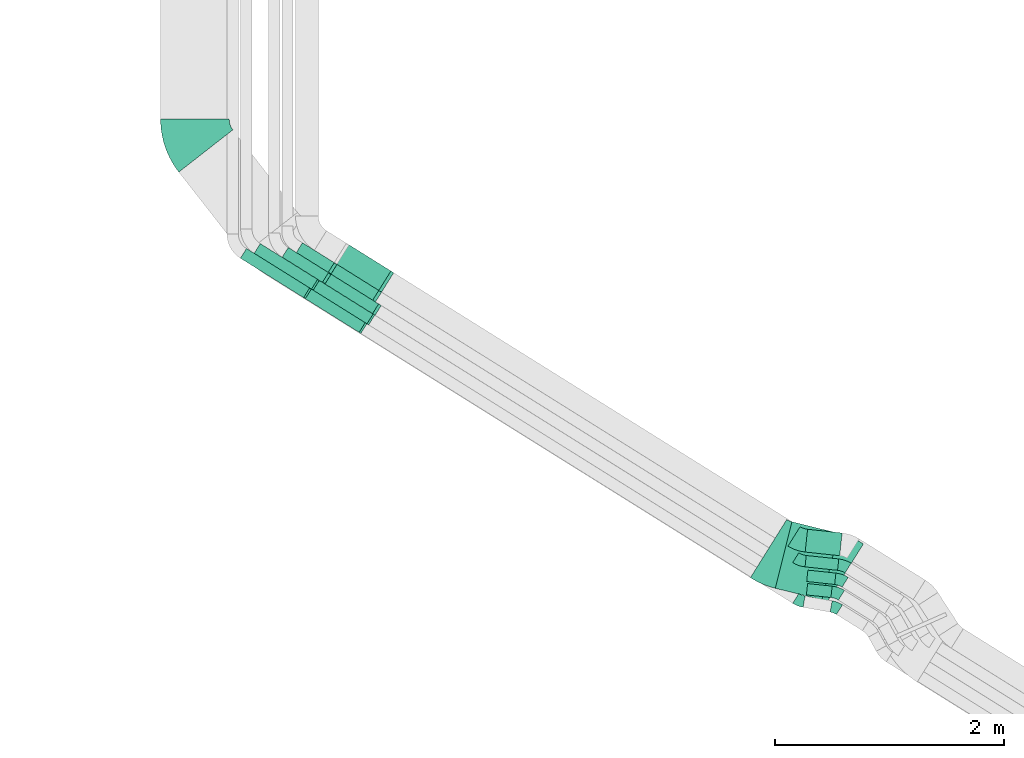
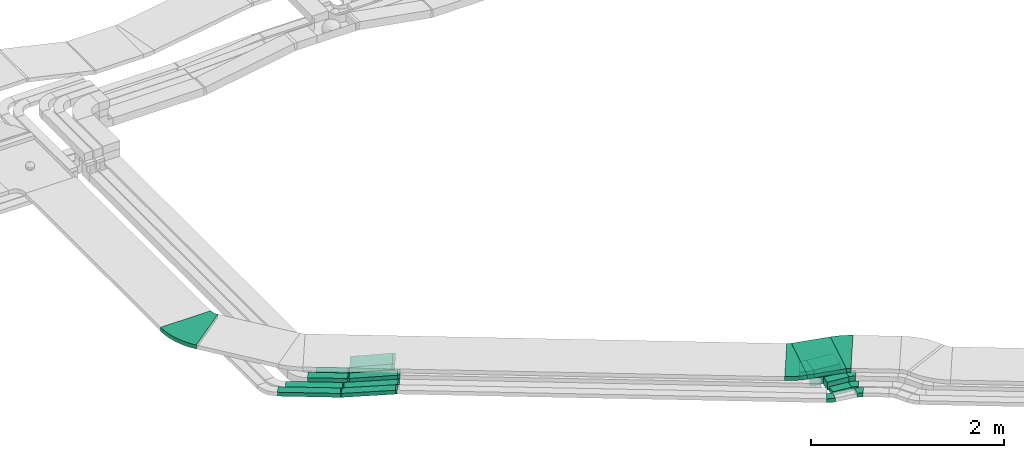
# One storey, part 5 of 28: 19 flow fittings, 14 flow segments.
"""IFC2X3 building model written with IfcOpenShell, lengths in millimetres."""

from ifc_helpers import new_model, entity, si_unit, converted_unit, derived_unit, direction, frame, frame_2d, origin, origin_2d_with_axis, place, context, subcontext, project, spatial, polyline, circle_curve, parameter, trimmed, segment, composite_curve, rectangle, outline, extrude, faceted_brep, source, transform, mapped, material, type_object, type_shapes, element, save


model = new_model("IFC2X3")

# Units and contexts
model_context = context("Model", 3, precision=0.01, world=origin(), true_north=direction((6.12303176911189e-17, 1.0)))
body_context = subcontext(model_context, "Body", "Model", "MODEL_VIEW")
ifc_project = project(units=[si_unit("LENGTHUNIT", "METRE", prefix="MILLI"), si_unit("AREAUNIT", "SQUARE_METRE"), si_unit("VOLUMEUNIT", "CUBIC_METRE"), converted_unit("PLANEANGLEUNIT", "DEGREE", entity("IfcRatioMeasure", 0.0174532925199433), si_unit("PLANEANGLEUNIT", "RADIAN"), dimensions=[0, 0, 0, 0, 0, 0, 0]), si_unit("MASSUNIT", "GRAM", prefix="KILO"), derived_unit("MASSDENSITYUNIT", [(si_unit("MASSUNIT", "GRAM", prefix="KILO"), 1), (si_unit("LENGTHUNIT", "METRE"), -3)]), derived_unit("MOMENTOFINERTIAUNIT", [(si_unit("LENGTHUNIT", "METRE"), 4)]), si_unit("TIMEUNIT", "SECOND"), si_unit("FREQUENCYUNIT", "HERTZ"), si_unit("THERMODYNAMICTEMPERATUREUNIT", "DEGREE_CELSIUS"), derived_unit("THERMALTRANSMITTANCEUNIT", [(si_unit("MASSUNIT", "GRAM", prefix="KILO"), 1), (si_unit("THERMODYNAMICTEMPERATUREUNIT", "KELVIN"), -1), (si_unit("TIMEUNIT", "SECOND"), -3)]), derived_unit("VOLUMETRICFLOWRATEUNIT", [(si_unit("LENGTHUNIT", "METRE"), 3), (si_unit("TIMEUNIT", "SECOND"), -1)]), derived_unit("MASSFLOWRATEUNIT", [(si_unit("MASSUNIT", "GRAM", prefix="KILO"), 1), (si_unit("TIMEUNIT", "SECOND"), -1)]), derived_unit("ROTATIONALFREQUENCYUNIT", [(si_unit("TIMEUNIT", "SECOND"), -1)]), si_unit("ELECTRICCURRENTUNIT", "AMPERE"), si_unit("ELECTRICVOLTAGEUNIT", "VOLT"), si_unit("POWERUNIT", "WATT"), si_unit("FORCEUNIT", "NEWTON", prefix="KILO"), si_unit("ILLUMINANCEUNIT", "LUX"), si_unit("LUMINOUSFLUXUNIT", "LUMEN"), si_unit("LUMINOUSINTENSITYUNIT", "CANDELA"), derived_unit("USERDEFINED", [(si_unit("MASSUNIT", "GRAM", prefix="KILO"), -1), (si_unit("LENGTHUNIT", "METRE"), -2), (si_unit("TIMEUNIT", "SECOND"), 3), (si_unit("LUMINOUSFLUXUNIT", "LUMEN"), 1)]), derived_unit("LINEARVELOCITYUNIT", [(si_unit("LENGTHUNIT", "METRE"), 1), (si_unit("TIMEUNIT", "SECOND"), -1)]), si_unit("PRESSUREUNIT", "PASCAL"), derived_unit("USERDEFINED", [(si_unit("LENGTHUNIT", "METRE"), -2), (si_unit("MASSUNIT", "GRAM", prefix="KILO"), 1), (si_unit("TIMEUNIT", "SECOND"), -2)]), derived_unit("LINEARFORCEUNIT", [(si_unit("MASSUNIT", "GRAM", prefix="KILO"), 1), (si_unit("LENGTHUNIT", "METRE"), 1), (si_unit("TIMEUNIT", "SECOND"), -2), (si_unit("LENGTHUNIT", "METRE"), -1)]), derived_unit("PLANARFORCEUNIT", [(si_unit("MASSUNIT", "GRAM", prefix="KILO"), 1), (si_unit("LENGTHUNIT", "METRE"), 1), (si_unit("TIMEUNIT", "SECOND"), -2), (si_unit("LENGTHUNIT", "METRE"), -2)])], contexts=[model_context])

# Site, building, storey
site_placement = place(None, origin())
site = spatial("IfcSite", under=ifc_project, at=site_placement, CompositionType="ELEMENT")
building_placement = place(site_placement, origin())
building = spatial("IfcBuilding", under=site, at=building_placement, CompositionType="ELEMENT")
storey_placement = place(building_placement, frame((0.0, 0.0, 4200.0)))
storey = spatial("IfcBuildingStorey", under=building, at=storey_placement, CompositionType="ELEMENT", Elevation=4200.0)

# Flow segments
cable_carrier_segment_type = type_object("IfcCableCarrierSegmentType", PredefinedType="CABLETRAYSEGMENT")
flow_segment_1_placement = place(storey_placement, frame((11021.96, 6012.63, 2780.0)))
element("IfcFlowSegment", 1, at=flow_segment_1_placement, inside=storey, type_object=cable_carrier_segment_type, context=body_context, shape_type="SweptSolid", body=[
    extrude(rectangle(XDim=590.779348946736, YDim=99.9999999999992, at=origin_2d_with_axis()), frame((277.0, 198.94, 0.0), z_axis=(0.0, 0.0, 1.0), x_axis=(-0.848048096156395, 0.529919264233255, 0.0)), (0.0, 0.0, 1.0), 49.9999999999995),
])
flow_segment_2_placement = place(storey_placement, frame((10901.96, 5937.63, 2780.0)))
element("IfcFlowSegment", 2, at=flow_segment_2_placement, inside=storey, type_object=cable_carrier_segment_type, context=body_context, shape_type="SweptSolid", body=[
    extrude(rectangle(XDim=650.976943556377, YDim=99.9999999999992, at=origin_2d_with_axis()), frame((302.53, 214.89, 0.0), z_axis=(0.0, 0.0, 1.0), x_axis=(-0.848048096156398, 0.529919264233251, 0.0)), (0.0, 0.0, 1.0), 49.9999999999994),
])
flow_segment_3_placement = place(storey_placement, frame((15850.33, 3315.86, 2836.0)))
element("IfcFlowSegment", 3, at=flow_segment_3_placement, inside=storey, type_object=cable_carrier_segment_type, context=body_context, shape_type="SweptSolid", body=[
    extrude(rectangle(XDim=215.79362758406, YDim=99.9999999999994, at=origin_2d_with_axis()), frame((112.59, 61.16, 0.0), z_axis=(0.0, 0.0, 1.0), x_axis=(0.994358083083249, -0.106075457137867, 0.0)), (0.0, 0.0, 1.0), 49.9999999999994),
])
flow_segment_4_placement = place(storey_placement, frame((15852.98, 3430.12, 2836.0)))
element("IfcFlowSegment", 4, at=flow_segment_4_placement, inside=storey, type_object=cable_carrier_segment_type, context=body_context, shape_type="SweptSolid", body=[
    extrude(rectangle(XDim=245.980376559461, YDim=99.9999999999996, at=origin_2d_with_axis()), frame((127.6, 62.76, 0.0), z_axis=(0.0, 0.0, 1.0), x_axis=(0.994358083083258, -0.106075457137776, 0.0)), (0.0, 0.0, 1.0), 99.9999999999989),
])
flow_segment_5_placement = place(storey_placement, frame((15838.53, 3553.72, 2836.0)))
element("IfcFlowSegment", 5, at=flow_segment_5_placement, inside=storey, type_object=cable_carrier_segment_type, context=body_context, shape_type="SweptSolid", body=[
    extrude(rectangle(XDim=285.980376559459, YDim=99.9999999999996, at=origin_2d_with_axis()), frame((147.49, 64.89, 0.0), z_axis=(0.0, 0.0, 1.0), x_axis=(0.994358083083257, -0.106075457137787, 0.0)), (0.0, 0.0, 1.0), 99.9999999999989),
])
flow_segment_6_placement = place(storey_placement, frame((15839.58, 3681.5, 2836.0)))
element("IfcFlowSegment", 6, at=flow_segment_6_placement, inside=storey, type_object=cable_carrier_segment_type, context=body_context, shape_type="SweptSolid", body=[
    extrude(rectangle(XDim=303.568110682782, YDim=200.0, at=origin_2d_with_axis()), frame((161.54, 115.54, 0.0), z_axis=(0.0, 0.0, 1.0), x_axis=(0.994358083083256, -0.106075457137793, 0.0)), (0.0, 0.0, 1.0), 99.9999999999989),
])
flow_segment_7_placement = place(storey_placement, frame((15578.61, 3295.28, 3108.85)))
element("IfcFlowSegment", 7, at=flow_segment_7_placement, inside=storey, type_object=cable_carrier_segment_type, context=body_context, shape_type="SweptSolid", body=[
    extrude(rectangle(XDim=419.986776604596, YDim=600.000000000001, at=origin_2d_with_axis()), frame((276.33, 341.89, 0.0), z_axis=(0.0, 0.0, 1.0), x_axis=(0.970295726275994, -0.241921895599679, 0.0)), (0.0, 0.0, 1.0), 49.9999999999995),
])
flow_segment_8_placement = place(storey_placement, frame((11464.95, 5631.66, 2780.86)))
element("IfcFlowSegment", 8, at=flow_segment_8_placement, inside=storey, type_object=cable_carrier_segment_type, context=body_context, shape_type="SweptSolid", body=[
    extrude(rectangle(XDim=50.0000000000007, YDim=100.0, at=frame_2d((0.0, 0.0), x_axis=(0.0, 1.0))), frame((28.55, 340.27, 24.88), z_axis=(0.844053853043885, -0.527423384128046, 0.0969415650621141), x_axis=(0.529919264233164, 0.848048096156452, 0.0)), (0.0, 0.0, 1.0), 562.323215441914),
])
flow_segment_9_placement = place(storey_placement, frame((11533.9, 5706.65, 2780.86)))
element("IfcFlowSegment", 9, at=flow_segment_9_placement, inside=storey, type_object=cable_carrier_segment_type, context=body_context, shape_type="SweptSolid", body=[
    extrude(rectangle(XDim=50.0000000000008, YDim=99.9999999999974, at=origin_2d_with_axis()), frame((28.55, 340.27, 24.88), z_axis=(0.844053853043877, -0.527423384128054, 0.0969415650621368), x_axis=(-0.0822111096893616, 0.0513712028313554, 0.995290074783881)), (0.0, 0.0, 1.0), 562.323215441913),
])
flow_segment_10_placement = place(storey_placement, frame((11632.32, 5792.33, 2781.42)))
element("IfcFlowSegment", 10, at=flow_segment_10_placement, inside=storey, type_object=cable_carrier_segment_type, context=body_context, shape_type="SweptSolid", body=[
    extrude(rectangle(XDim=100.0, YDim=100.000000000001, at=origin_2d_with_axis()), frame((31.02, 310.67, 49.71), z_axis=(0.843210160257302, -0.526896186363397, 0.106663182188436), x_axis=(-0.0904555085848854, 0.0565228750260753, 0.994295210470933)), (0.0, 0.0, 1.0), 503.785479436427),
])
flow_segment_11_placement = place(storey_placement, frame((11266.96, 6071.81, 2780.0)))
element("IfcFlowSegment", 11, at=flow_segment_11_placement, inside=storey, type_object=cable_carrier_segment_type, context=body_context, shape_type="SweptSolid", body=[
    extrude(rectangle(XDim=414.985433178406, YDim=99.9999999999999, at=origin_2d_with_axis()), frame((202.46, 152.36, 0.0), z_axis=(0.0, 0.0, 1.0), x_axis=(-0.848048096156469, 0.529919264233136, 0.0)), (0.0, 0.0, 1.0), 100.000000000002),
])
flow_segment_12_placement = place(storey_placement, frame((11683.6, 5909.58, 2781.71)))
element("IfcFlowSegment", 12, at=flow_segment_12_placement, inside=storey, type_object=cable_carrier_segment_type, context=body_context, shape_type="SweptSolid", body=[
    extrude(rectangle(XDim=100.0, YDim=100.0, at=frame_2d((0.0, 0.0), x_axis=(0.0, 1.0))), frame((31.57, 279.84, 49.64), z_axis=(0.841952241120385, -0.526110151247443, 0.119685138704662), x_axis=(0.529919264233164, 0.848048096156452, 0.0)), (0.0, 0.0, 1.0), 445.282079813443),
])
flow_segment_13_placement = place(storey_placement, frame((11736.83, 5994.77, 2781.71)))
element("IfcFlowSegment", 13, at=flow_segment_13_placement, inside=storey, type_object=cable_carrier_segment_type, context=body_context, shape_type="SweptSolid", body=[
    extrude(rectangle(XDim=99.9999999999993, YDim=200.0, at=frame_2d((0.0, 0.0), x_axis=(0.0, 1.0))), frame((58.07, 322.24, 49.64), z_axis=(0.841952241120382, -0.526110151247425, 0.119685138704764), x_axis=(0.529919264233197, 0.848048096156431, 0.0)), (0.0, 0.0, 1.0), 445.282079812818),
])
flow_segment_14_placement = place(storey_placement, frame((11391.08, 6158.96, 2780.0)))
element("IfcFlowSegment", 14, at=flow_segment_14_placement, inside=storey, type_object=cable_carrier_segment_type, context=body_context, shape_type="SweptSolid", body=[
    extrude(rectangle(XDim=328.386911704391, YDim=99.9999999999992, at=origin_2d_with_axis()), frame((165.74, 129.41, 0.0), z_axis=(0.0, 0.0, 1.0), x_axis=(-0.848048096156503, 0.529919264233081, 0.0)), (0.0, 0.0, 1.0), 99.9999999999989),
])

# Flow fittings
ifc_material = material()
cable_carrier_fitting_type_1 = type_object("IfcCableCarrierFittingType", PredefinedType="NOTDEFINED", material=ifc_material)
shared_shape_1 = source(origin(), body_context, "Body", "Brep", [
    faceted_brep([(-7.67, -25.0, 50.0), (-7.67, 25.0, 50.0), (-7.67, 25.0, 47.46), (-7.67, -22.46, 47.46), (-7.67, -22.46, -47.46), (-7.67, 25.0, -47.46), (-7.67, 25.0, -50.0), (-7.67, -25.0, -50.0), (10.06, -24.14, 50.0), (10.06, -24.14, -50.0), (5.21, 25.63, -50.0), (5.21, 25.63, -47.46), (9.81, -21.61, -47.46), (9.81, -21.61, 47.46), (5.21, 25.63, 47.46), (5.21, 25.63, 50.0), (1.21, -25.0, 50.0), (-1.21, 25.0, 50.0), (-1.21, 25.0, 47.46), (1.09, -22.46, 47.46), (1.09, -22.46, -47.46), (-1.21, 25.0, -47.46), (-1.21, 25.0, -50.0), (1.21, -25.0, -50.0)], [[[0, 1, 2, 3, 4, 5, 6, 7]], [[8, 9, 10, 11, 12, 13, 14, 15]], [[1, 0, 16, 8, 15, 17]], [[2, 1, 17, 18]], [[3, 2, 18, 14, 13, 19]], [[4, 3, 19, 20]], [[5, 4, 20, 12, 11, 21]], [[6, 5, 21, 22]], [[7, 6, 22, 10, 9, 23]], [[0, 7, 23, 16]], [[18, 17, 15, 14]], [[20, 19, 13, 12]], [[22, 21, 11, 10]], [[16, 23, 9, 8]]]),
])
type_shapes(cable_carrier_fitting_type_1, [shared_shape_1])
for number, where, z_axis, x_axis in (
    (15, (11974.6, 5671.3, 2861.0), (-0.529919264233211, -0.848048096156423, 0.0), (-0.848048096156423, 0.529919264233211, 0.0)),
    (16, (12043.55, 5746.29, 2861.0), (-0.52991926423321, -0.848048096156423, 0.0), (-0.848048096156423, 0.52991926423321, 0.0)),
    (17, (11555.97, 6050.97, 2805.0), (0.529919264233259, 0.848048096156392, 0.0), (-0.84405385304387, 0.527423384128066, -0.0969415650621308)),
    (18, (11487.02, 5975.97, 2805.0), (0.529919264233254, 0.848048096156395, 0.0), (-0.844053853043888, 0.527423384128036, -0.0969415650621345)),
):
    element("IfcFlowFitting", number, at=place(storey_placement, frame(where, z_axis=z_axis, x_axis=x_axis)), inside=storey, type_object=cable_carrier_fitting_type_1, material=ifc_material, context=body_context, shape_type="MappedRepresentation", body=[
        mapped(shared_shape_1, transform((0.0, 0.0, 0.0), scale=1.0)),
    ])
cable_carrier_fitting_type_2 = type_object("IfcCableCarrierFittingType", PredefinedType="NOTDEFINED", material=ifc_material)
shared_shape_2 = source(origin(), body_context, "Body", "Brep", [
    faceted_brep([(-10.62, -50.0, 50.0), (-10.62, 50.0, 50.0), (-10.62, 50.0, 47.46), (-10.62, -47.46, 47.46), (-10.62, -47.46, -47.46), (-10.62, 50.0, -47.46), (-10.62, 50.0, -50.0), (-10.62, -50.0, -50.0), (15.89, -48.58, 50.0), (15.89, -48.58, -50.0), (5.22, 50.85, -50.0), (5.22, 50.85, -47.46), (15.62, -46.06, -47.46), (15.62, -46.06, 47.46), (5.22, 50.85, 47.46), (5.22, 50.85, 50.0), (2.67, -50.0, 50.0), (-2.67, 50.0, 50.0), (-2.67, 50.0, 47.46), (2.54, -47.46, 47.46), (2.54, -47.46, -47.46), (-2.67, 50.0, -47.46), (-2.67, 50.0, -50.0), (2.67, -50.0, -50.0)], [[[0, 1, 2, 3, 4, 5, 6, 7]], [[8, 9, 10, 11, 12, 13, 14, 15]], [[1, 0, 16, 8, 15, 17]], [[2, 1, 17, 18]], [[3, 2, 18, 14, 13, 19]], [[4, 3, 19, 20]], [[5, 4, 20, 12, 11, 21]], [[6, 5, 21, 22]], [[7, 6, 22, 10, 9, 23]], [[0, 7, 23, 16]], [[18, 17, 15, 14]], [[20, 19, 13, 12]], [[22, 21, 11, 10]], [[16, 23, 9, 8]]]),
])
type_shapes(cable_carrier_fitting_type_2, [shared_shape_2])
for number, where, z_axis, x_axis in (
    (19, (12097.09, 5831.96, 2886.0), (-0.52991926423321, -0.848048096156423, 0.0), (-0.848048096156423, 0.52991926423321, 0.0)),
    (20, (11654.39, 6108.59, 2830.0), (0.529919264233145, 0.848048096156463, 0.0), (-0.843210160257299, 0.526896186363399, -0.106663182188447)),
):
    element("IfcFlowFitting", number, at=place(storey_placement, frame(where, z_axis=z_axis, x_axis=x_axis)), inside=storey, type_object=cable_carrier_fitting_type_2, material=ifc_material, context=body_context, shape_type="MappedRepresentation", body=[
        mapped(shared_shape_2, transform((0.0, 0.0, 0.0), scale=1.0)),
    ])
cable_carrier_fitting_type_3 = type_object("IfcCableCarrierFittingType", PredefinedType="NOTDEFINED", material=ifc_material)
shared_shape_3 = source(origin(), body_context, "Body", "Brep", [
    faceted_brep([(-11.31, -50.0, 50.0), (-11.31, 50.0, 50.0), (-11.31, 50.0, 47.46), (-11.31, -47.46, 47.46), (-11.31, -47.46, -47.46), (-11.31, 50.0, -47.46), (-11.31, 50.0, -50.0), (-11.31, -50.0, -50.0), (17.21, -48.29, 50.0), (17.21, -48.29, -50.0), (5.24, 50.99, -50.0), (5.24, 50.99, -47.46), (16.91, -45.77, -47.46), (16.91, -45.77, 47.46), (5.24, 50.99, 47.46), (5.24, 50.99, 50.0), (3.0, -50.0, 50.0), (-3.0, 50.0, 50.0), (-3.0, 50.0, 47.46), (2.85, -47.46, 47.46), (2.85, -47.46, -47.46), (-3.0, 50.0, -47.46), (-3.0, 50.0, -50.0), (3.0, -50.0, -50.0)], [[[0, 1, 2, 3, 4, 5, 6, 7]], [[8, 9, 10, 11, 12, 13, 14, 15]], [[1, 0, 16, 8, 15, 17]], [[2, 1, 17, 18]], [[3, 2, 18, 14, 13, 19]], [[4, 3, 19, 20]], [[5, 4, 20, 12, 11, 21]], [[6, 5, 21, 22]], [[7, 6, 22, 10, 9, 23]], [[0, 7, 23, 16]], [[18, 17, 15, 14]], [[20, 19, 13, 12]], [[22, 21, 11, 10]], [[16, 23, 9, 8]]]),
])
type_shapes(cable_carrier_fitting_type_3, [shared_shape_3])
for number, where, z_axis, x_axis in (
    (21, (11705.65, 6195.37, 2830.0), (-0.529919264233235, -0.848048096156407, 0.0), (0.848048096156407, -0.529919264233235, 0.0)),
    (22, (12099.6, 5949.21, 2886.0), (-0.529919264233217, -0.848048096156419, 0.0), (-0.848048096156419, 0.529919264233217, 0.0)),
):
    element("IfcFlowFitting", number, at=place(storey_placement, frame(where, z_axis=z_axis, x_axis=x_axis)), inside=storey, type_object=cable_carrier_fitting_type_3, material=ifc_material, context=body_context, shape_type="MappedRepresentation", body=[
        mapped(shared_shape_3, transform((0.0, 0.0, 0.0), scale=1.0)),
    ])
cable_carrier_fitting_type_4 = type_object("IfcCableCarrierFittingType", PredefinedType="NOTDEFINED", material=ifc_material)
shared_shape_4 = source(origin(), body_context, "Body", "Brep", [
    faceted_brep([(-11.31, -50.0, 100.0), (-11.31, 50.0, 100.0), (-11.31, 50.0, 97.46), (-11.31, -47.46, 97.46), (-11.31, -47.46, -97.46), (-11.31, 50.0, -97.46), (-11.31, 50.0, -100.0), (-11.31, -50.0, -100.0), (17.21, -48.29, 100.0), (17.21, -48.29, -100.0), (5.24, 50.99, -100.0), (5.24, 50.99, -97.46), (16.91, -45.77, -97.46), (16.91, -45.77, 97.46), (5.24, 50.99, 97.46), (5.24, 50.99, 100.0), (3.0, -50.0, 100.0), (-3.0, 50.0, 100.0), (-3.0, 50.0, 97.46), (2.85, -47.46, 97.46), (2.85, -47.46, -97.46), (-3.0, 50.0, -97.46), (-3.0, 50.0, -100.0), (3.0, -50.0, -100.0)], [[[0, 1, 2, 3, 4, 5, 6, 7]], [[8, 9, 10, 11, 12, 13, 14, 15]], [[1, 0, 16, 8, 15, 17]], [[2, 1, 17, 18]], [[3, 2, 18, 14, 13, 19]], [[4, 3, 19, 20]], [[5, 4, 20, 12, 11, 21]], [[6, 5, 21, 22]], [[7, 6, 22, 10, 9, 23]], [[0, 7, 23, 16]], [[18, 17, 15, 14]], [[20, 19, 13, 12]], [[22, 21, 11, 10]], [[16, 23, 9, 8]]]),
])
type_shapes(cable_carrier_fitting_type_4, [shared_shape_4])
flow_fitting_1_placement = place(storey_placement, frame((12179.33, 6076.8, 2886.0), z_axis=(0.529919264233213, 0.848048096156421, 0.0), x_axis=(0.841952241120384, -0.526110151247419, 0.119685138704774)))
element("IfcFlowFitting", 23, at=flow_fitting_1_placement, inside=storey, type_object=cable_carrier_fitting_type_4, material=ifc_material, context=body_context, shape_type="MappedRepresentation", body=[
    mapped(shared_shape_4, transform((0.0, 0.0, 0.0), scale=1.0)),
])
cable_carrier_fitting_type_5 = type_object("IfcCableCarrierFittingType", Name="470_DKC_S5_Variable Angle Elbow 0-45:-", PredefinedType="NOTDEFINED", material=ifc_material)
shared_shape_5 = source(origin(), body_context, "Body", "SweptSolid", [
    extrude(outline(composite_curve([segment(polyline([(-38.44, -57.38), (-37.44, -57.38)]), True, "CONTINUOUS"), segment(trimmed(circle_curve(frame_2d((-37.44, 192.62), x_axis=(0.0, -1.0)), 250.0), [parameter(0.0)], [parameter(22.0)], True, "PARAMETER"), True, "CONTINUOUS"), segment(polyline([(56.21, -39.17), (57.14, -38.8)]), True, "CONTINUOUS"), segment(polyline([(57.14, -38.8), (19.68, 53.92)]), True, "CONTINUOUS"), segment(polyline([(19.68, 53.92), (18.75, 53.55)]), True, "CONTINUOUS"), segment(trimmed(circle_curve(frame_2d((-37.44, 192.62), x_axis=(0.0, -1.0)), 150.0), [parameter(0.0)], [parameter(22.0)], True, "PARAMETER"), False, "CONTINUOUS"), segment(polyline([(-37.44, 42.62), (-38.44, 42.62)]), True, "CONTINUOUS"), segment(polyline([(-38.44, 42.62), (-38.44, -57.38)]), True, "CONTINUOUS")], self_intersect=False)), frame((-1.43, 7.38, -25.0)), (0.0, 0.0, 1.0), 50.0000000000001),
])
type_shapes(cable_carrier_fitting_type_5, [shared_shape_5])
for number, where, z_axis, x_axis, name in (
    (24, (15790.82, 3286.66, 2861.0), (0.0, 0.0, 1.0), (0.848048096156424, -0.529919264233208, 0.0), "470_DKC_S5_Variable Angle Elbow 0-45:-"),
    (25, (16105.96, 3231.09, 2861.0), (0.0, 0.0, 1.0), (-0.848048096156422, 0.529919264233211, 0.0), "470_DKC_S5_Variable Angle Elbow 0-45:-"),
):
    element("IfcFlowFitting", number, at=place(storey_placement, frame(where, z_axis=z_axis, x_axis=x_axis)), inside=storey, type_object=cable_carrier_fitting_type_5, material=ifc_material, Name=name, ObjectType="470_DKC_S5_Variable Angle Elbow 0-45:-", context=body_context, shape_type="MappedRepresentation", body=[
        mapped(shared_shape_5, transform((0.0, 0.0, 0.0), scale=1.0)),
    ])
cable_carrier_fitting_type_6 = type_object("IfcCableCarrierFittingType", Name="470_DKC_S5_Variable Angle Elbow 0-45:-", PredefinedType="NOTDEFINED", material=ifc_material)
shared_shape_6 = source(origin(), body_context, "Body", "SweptSolid", [
    extrude(outline(composite_curve([segment(polyline([(-44.67, -60.16), (-43.67, -60.16)]), True, "CONTINUOUS"), segment(trimmed(circle_curve(frame_2d((-43.67, 189.84), x_axis=(0.0, -1.0)), 250.0), [parameter(0.0)], [parameter(25.9108682245421)], True, "PARAMETER"), True, "CONTINUOUS"), segment(polyline([(65.57, -35.03), (66.47, -34.59)]), True, "CONTINUOUS"), segment(polyline([(66.47, -34.59), (22.77, 55.35)]), True, "CONTINUOUS"), segment(polyline([(22.77, 55.35), (21.87, 54.92)]), True, "CONTINUOUS"), segment(trimmed(circle_curve(frame_2d((-43.67, 189.84), x_axis=(0.0, -1.0)), 150.0), [parameter(0.0)], [parameter(25.9108682245421)], True, "PARAMETER"), False, "CONTINUOUS"), segment(polyline([(-43.67, 39.84), (-44.67, 39.84)]), True, "CONTINUOUS"), segment(polyline([(-44.67, 39.84), (-44.67, -60.16)]), True, "CONTINUOUS")], self_intersect=False)), frame((-2.34, 10.16, -25.0)), (0.0, 0.0, 1.0), 50.0),
])
type_shapes(cable_carrier_fitting_type_6, [shared_shape_6])
flow_fitting_2_placement = place(storey_placement, frame((16116.95, 3360.59, 2861.0), z_axis=(0.0, 0.0, 1.0), x_axis=(-0.848048096156432, 0.529919264233196, 0.0)))
element("IfcFlowFitting", 26, at=flow_fitting_2_placement, inside=storey, type_object=cable_carrier_fitting_type_6, material=ifc_material, Name="470_DKC_S5_Variable Angle Elbow 0-45:-", ObjectType="470_DKC_S5_Variable Angle Elbow 0-45:-", context=body_context, shape_type="MappedRepresentation", body=[
    mapped(shared_shape_6, transform((0.0, 0.0, 0.0), scale=1.0)),
])
cable_carrier_fitting_type_7 = type_object("IfcCableCarrierFittingType", Name="470_DKC_S5_Variable Angle Elbow 0-45:-", PredefinedType="NOTDEFINED", material=ifc_material)
shared_shape_7 = source(origin(), body_context, "Body", "SweptSolid", [
    extrude(outline(composite_curve([segment(polyline([(-44.67, -60.16), (-43.67, -60.16)]), True, "CONTINUOUS"), segment(trimmed(circle_curve(frame_2d((-43.67, 189.84), x_axis=(0.0, -1.0)), 250.0), [parameter(0.0)], [parameter(25.9108682245476)], True, "PARAMETER"), True, "CONTINUOUS"), segment(polyline([(65.57, -35.03), (66.47, -34.59)]), True, "CONTINUOUS"), segment(polyline([(66.47, -34.59), (22.77, 55.35)]), True, "CONTINUOUS"), segment(polyline([(22.77, 55.35), (21.87, 54.92)]), True, "CONTINUOUS"), segment(trimmed(circle_curve(frame_2d((-43.67, 189.84), x_axis=(0.0, -1.0)), 150.0), [parameter(0.0)], [parameter(25.9108682245476)], True, "PARAMETER"), False, "CONTINUOUS"), segment(polyline([(-43.67, 39.84), (-44.67, 39.84)]), True, "CONTINUOUS"), segment(polyline([(-44.67, 39.84), (-44.67, -60.16)]), True, "CONTINUOUS")], self_intersect=False)), frame((-2.34, 10.16, -50.0)), (0.0, 0.0, 1.0), 100.0),
])
type_shapes(cable_carrier_fitting_type_7, [shared_shape_7])
for number, where, z_axis, x_axis, name in (
    (27, (16149.62, 3474.85, 2886.0), (0.0, 0.0, 1.0), (-0.848048096156424, 0.529919264233209, 0.0), "470_DKC_S5_Variable Angle Elbow 0-45:-"),
    (28, (15797.09, 3638.76, 2886.0), (0.0, 0.0, 1.0), (0.848048096156421, -0.529919264233214, 0.0), "470_DKC_S5_Variable Angle Elbow 0-45:-"),
    (29, (16174.94, 3598.45, 2886.0), (0.0, 0.0, 1.0), (-0.848048096156423, 0.529919264233211, 0.0), "470_DKC_S5_Variable Angle Elbow 0-45:-"),
):
    element("IfcFlowFitting", number, at=place(storey_placement, frame(where, z_axis=z_axis, x_axis=x_axis)), inside=storey, type_object=cable_carrier_fitting_type_7, material=ifc_material, Name=name, ObjectType="470_DKC_S5_Variable Angle Elbow 0-45:-", context=body_context, shape_type="MappedRepresentation", body=[
        mapped(shared_shape_7, transform((0.0, 0.0, 0.0), scale=1.0)),
    ])
cable_carrier_fitting_type_8 = type_object("IfcCableCarrierFittingType", Name="470_DKC_S5_Variable Angle Elbow 0-45:-", PredefinedType="NOTDEFINED", material=ifc_material)
shared_shape_8 = source(origin(), body_context, "Body", "SweptSolid", [
    extrude(outline(composite_curve([segment(polyline([(-55.6, -112.67), (-54.6, -112.67)]), True, "CONTINUOUS"), segment(trimmed(circle_curve(frame_2d((-54.6, 237.33), x_axis=(0.0, -1.0)), 350.0), [parameter(0.0)], [parameter(25.9108682245477)], True, "PARAMETER"), True, "CONTINUOUS"), segment(polyline([(98.34, -77.49), (99.24, -77.05)]), True, "CONTINUOUS"), segment(polyline([(99.24, -77.05), (11.85, 102.84)]), True, "CONTINUOUS"), segment(polyline([(11.85, 102.84), (10.95, 102.4)]), True, "CONTINUOUS"), segment(trimmed(circle_curve(frame_2d((-54.6, 237.33), x_axis=(0.0, -1.0)), 150.0), [parameter(0.0)], [parameter(25.9108682245477)], True, "PARAMETER"), False, "CONTINUOUS"), segment(polyline([(-54.6, 87.33), (-55.6, 87.33)]), True, "CONTINUOUS"), segment(polyline([(-55.6, 87.33), (-55.6, -112.67)]), True, "CONTINUOUS")], self_intersect=False)), frame((-2.92, 12.67, -50.0)), (0.0, 0.0, 1.0), 100.0),
])
type_shapes(cable_carrier_fitting_type_8, [shared_shape_8])
flow_fitting_3_placement = place(storey_placement, frame((15792.01, 3819.34, 2886.0), z_axis=(0.0, 0.0, 1.0), x_axis=(0.848048096156422, -0.529919264233211, 0.0)))
element("IfcFlowFitting", 30, at=flow_fitting_3_placement, inside=storey, type_object=cable_carrier_fitting_type_8, material=ifc_material, Name="470_DKC_S5_Variable Angle Elbow 0-45:-", ObjectType="470_DKC_S5_Variable Angle Elbow 0-45:-", context=body_context, shape_type="MappedRepresentation", body=[
    mapped(shared_shape_8, transform((0.0, 0.0, 0.0), scale=1.0)),
])
cable_carrier_fitting_type_9 = type_object("IfcCableCarrierFittingType", Name="470_DKC_S5_Variable Angle Elbow 0-45:-", PredefinedType="NOTDEFINED", material=ifc_material)
shared_shape_9 = source(origin(), body_context, "Body", "SweptSolid", [
    extrude(outline(composite_curve([segment(polyline([(-70.52, -311.09), (-69.52, -311.09)]), True, "CONTINUOUS"), segment(trimmed(circle_curve(frame_2d((-69.52, 438.91), x_axis=(0.0, -1.0)), 750.0), [parameter(0.0)], [parameter(17.9999999999994)], True, "PARAMETER"), True, "CONTINUOUS"), segment(polyline([(162.25, -274.38), (163.2, -274.07)]), True, "CONTINUOUS"), segment(polyline([(163.2, -274.07), (-22.21, 296.56)]), True, "CONTINUOUS"), segment(polyline([(-22.21, 296.56), (-23.16, 296.25)]), True, "CONTINUOUS"), segment(trimmed(circle_curve(frame_2d((-69.52, 438.91), x_axis=(0.0, -1.0)), 150.0), [parameter(0.0)], [parameter(17.9999999999994)], True, "PARAMETER"), False, "CONTINUOUS"), segment(polyline([(-69.52, 288.91), (-70.52, 288.91)]), True, "CONTINUOUS"), segment(polyline([(-70.52, 288.91), (-70.52, -311.09)]), True, "CONTINUOUS")], self_intersect=False)), frame((-1.76, 11.09, -25.0)), (0.0, 0.0, 1.0), 50.0000000000027),
])
type_shapes(cable_carrier_fitting_type_9, [shared_shape_9])
for number, where, z_axis, x_axis, name in (
    (31, (15581.06, 3705.45, 3133.85), (0.0, 0.0, 1.0), (0.84804809615643, -0.529919264233199, 0.0), "470_DKC_S5_Variable Angle Elbow 0-45:-"),
    (32, (16128.82, 3568.88, 3133.85), (0.0, 0.0, 1.0), (-0.848048096156421, 0.529919264233213, 0.0), "470_DKC_S5_Variable Angle Elbow 0-45:-"),
):
    element("IfcFlowFitting", number, at=place(storey_placement, frame(where, z_axis=z_axis, x_axis=x_axis)), inside=storey, type_object=cable_carrier_fitting_type_9, material=ifc_material, Name=name, ObjectType="470_DKC_S5_Variable Angle Elbow 0-45:-", context=body_context, shape_type="MappedRepresentation", body=[
        mapped(shared_shape_9, transform((0.0, 0.0, 0.0), scale=1.0)),
    ])
cable_carrier_fitting_type_10 = type_object("IfcCableCarrierFittingType", Name="470_DKC_S5_Variable Angle Elbow 0-45:-", PredefinedType="NOTDEFINED", material=ifc_material)
shared_shape_10 = source(origin(), body_context, "Body", "SweptSolid", [
    extrude(outline(composite_curve([segment(polyline([(-139.47, -347.85), (-138.47, -347.85)]), True, "CONTINUOUS"), segment(trimmed(circle_curve(frame_2d((-138.47, 402.15), x_axis=(0.0, -1.0)), 750.0), [parameter(0.0)], [parameter(37.9999999999995)], True, "PARAMETER"), True, "CONTINUOUS"), segment(polyline([(323.28, -188.86), (324.06, -188.24)]), True, "CONTINUOUS"), segment(polyline([(324.06, -188.24), (-45.33, 284.56)]), True, "CONTINUOUS"), segment(polyline([(-45.33, 284.56), (-46.12, 283.95)]), True, "CONTINUOUS"), segment(trimmed(circle_curve(frame_2d((-138.47, 402.15), x_axis=(0.0, -1.0)), 150.0), [parameter(0.0)], [parameter(37.9999999999995)], True, "PARAMETER"), False, "CONTINUOUS"), segment(polyline([(-138.47, 252.15), (-139.47, 252.15)]), True, "CONTINUOUS"), segment(polyline([(-139.47, 252.15), (-139.47, -347.85)]), True, "CONTINUOUS")], self_intersect=False)), frame((-16.48, 47.85, -25.0)), (0.0, 0.0, 1.0), 50.0000000000051),
])
type_shapes(cable_carrier_fitting_type_10, [shared_shape_10])
flow_fitting_4_placement = place(storey_placement, frame((10503.59, 7343.31, 3133.85), z_axis=(0.0, 0.0, 1.0), x_axis=(0.0, -1.0, 0.0)))
element("IfcFlowFitting", 33, at=flow_fitting_4_placement, inside=storey, type_object=cable_carrier_fitting_type_10, material=ifc_material, Name="470_DKC_S5_Variable Angle Elbow 0-45:-", ObjectType="470_DKC_S5_Variable Angle Elbow 0-45:-", context=body_context, shape_type="MappedRepresentation", body=[
    mapped(shared_shape_10, transform((0.0, 0.0, 0.0), scale=1.0)),
])

save(model, "model.ifc")
